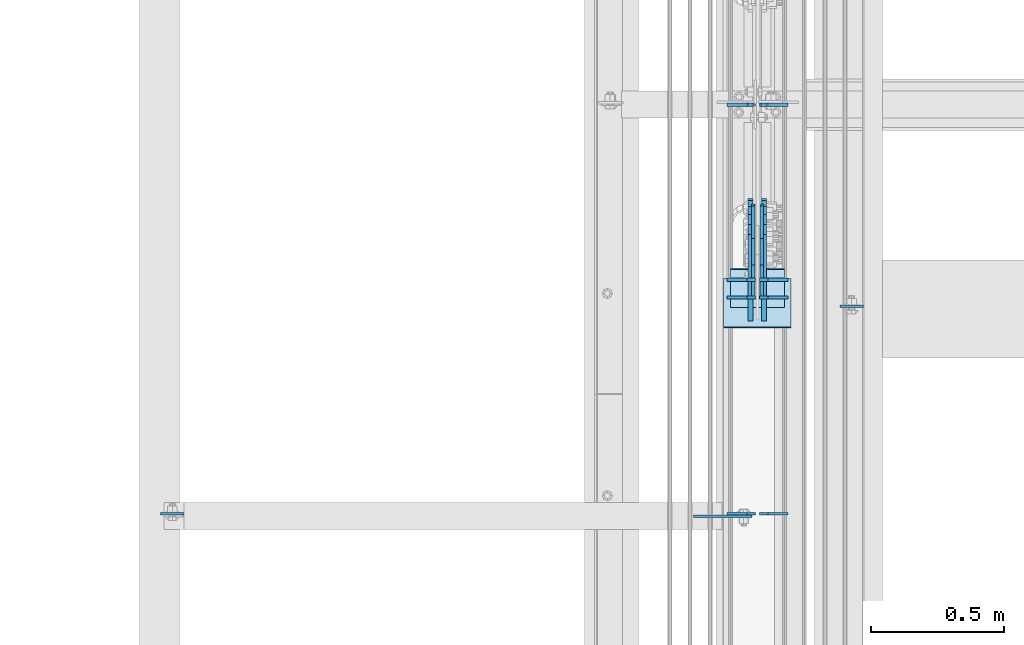
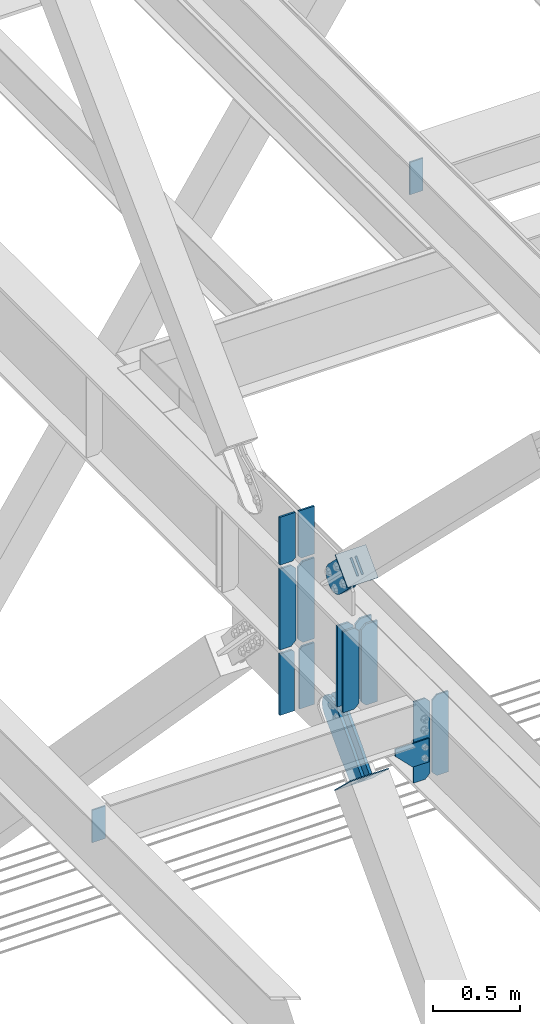
# One storey, part 3530 of 3843: 21 plates, 10 elements without a shape of their own.
"""IFC2X3 building model written with IfcOpenShell, lengths in millimetres."""

from ifc_helpers import new_model, si_unit, frame, origin_with_axes, place, context, subcontext, project, spatial, faceted_brep, material, type_object, element, aggregate, save


model = new_model("IFC2X3")

# Units and contexts
model_context = context("Model", 3, precision=1e-05, world=origin_with_axes())
body_context = subcontext(model_context, "Body", "Model", "MODEL_VIEW")
ifc_project = project(units=[si_unit("LENGTHUNIT", "METRE", prefix="MILLI"), si_unit("AREAUNIT", "SQUARE_METRE"), si_unit("VOLUMEUNIT", "CUBIC_METRE"), si_unit("MASSUNIT", "GRAM", prefix="KILO"), si_unit("TIMEUNIT", "SECOND"), si_unit("PLANEANGLEUNIT", "RADIAN"), si_unit("SOLIDANGLEUNIT", "STERADIAN"), si_unit("THERMODYNAMICTEMPERATUREUNIT", "DEGREE_CELSIUS"), si_unit("LUMINOUSINTENSITYUNIT", "LUMEN")], contexts=[model_context])

# Site, building, storey
site_placement = place(None, origin_with_axes())
site = spatial("IfcSite", under=ifc_project, at=site_placement, CompositionType="ELEMENT")
building_placement = place(site_placement, origin_with_axes())
building = spatial("IfcBuilding", under=site, at=building_placement, Name="Undefined", CompositionType="ELEMENT")
storey_placement = place(building_placement, origin_with_axes())
storey = spatial("IfcBuildingStorey", under=building, at=storey_placement, Name="Undefined", CompositionType="ELEMENT", Elevation=0.0)

# Assembly, plate
assembly_1_placement = place(storey_placement, origin_with_axes())
assembly_1 = element("IfcElementAssembly", 1, at=assembly_1_placement, inside=storey, Name="BEAM", AssemblyPlace="NOTDEFINED", PredefinedType="RIGID_FRAME")
ifc_material_1 = material(Name="STEEL/A572-50")
plate_type_1 = type_object("IfcPlateType", PredefinedType="NOTDEFINED")
plate_1_placement = place(assembly_1_placement, frame((77323.15625, 97627.082821, 39573.2), z_axis=(1.0, 0.0, 0.0), x_axis=(0.0, 0.0, -1.0)))
plate_1 = element("IfcPlate", 2, at=plate_1_placement, type_object=plate_type_1, material=ifc_material_1, Name="PLATE", context=body_context, shape_type="Brep", body=[
    faceted_brep([(0.0, -4.76249999999709, 0.0), (0.0, -4.76249999999709, 88.9000015258789), (0.0, 4.76249999999709, 88.9000015258789), (0.0, 4.76249999999709, 0.0), (228.600006102781, -4.7625000004191, 88.9000015257589), (228.600006102781, 4.76249999954598, 88.9000015257443), (228.600006103079, -4.7625000004482, 7.27595761418343e-12), (228.600006103079, 4.76249999954598, -7.27595761418343e-12)], [[[0, 1, 2, 3]], [[1, 4, 5, 2]], [[4, 6, 7, 5]], [[6, 0, 3, 7]], [[5, 7, 3, 2]], [[6, 4, 1, 0]]]),
])
aggregate(assembly_1, [plate_1])

assembly_2_placement = place(storey_placement, origin_with_axes())
assembly_2 = element("IfcElementAssembly", 3, at=assembly_2_placement, inside=storey, Name="BEAM", AssemblyPlace="NOTDEFINED", PredefinedType="RIGID_FRAME")
plate_2_placement = place(assembly_2_placement, frame((74764.503124, 96845.4375, 36398.2000000005), z_axis=(1.0, 0.0, 0.0), x_axis=(0.0, 0.0, -1.0)))
plate_2 = element("IfcPlate", 4, at=plate_2_placement, type_object=plate_type_1, material=ifc_material_1, Name="PLATE", context=body_context, shape_type="Brep", body=[
    faceted_brep([(0.0, -4.76249999999709, 0.0), (0.0, -4.76249999999709, 88.9000015258789), (0.0, 4.76249999999709, 88.9000015258789), (0.0, 4.76249999999709, 0.0), (228.600006102781, -4.7625000004191, 88.9000015257589), (228.600006102781, 4.76249999954598, 88.9000015257443), (228.600006103079, -4.7625000004482, 7.27595761418343e-12), (228.600006103079, 4.76249999954598, -7.27595761418343e-12)], [[[0, 1, 2, 3]], [[1, 4, 5, 2]], [[4, 6, 7, 5]], [[6, 0, 3, 7]], [[5, 7, 3, 2]], [[6, 4, 1, 0]]]),
])
aggregate(assembly_2, [plate_2])

# Assembly, plates
assembly_3_placement = place(storey_placement, origin_with_axes())
assembly_3 = element("IfcElementAssembly", 5, at=assembly_3_placement, inside=storey, Name="BEAM", AssemblyPlace="NOTDEFINED", PredefinedType="RIGID_FRAME")
plate_type_2 = type_object("IfcPlateType", PredefinedType="NOTDEFINED")
plate_3_placement = place(assembly_3_placement, frame((77019.94375, 96845.4379999161, 35840.9875), z_axis=(0.0, 0.0, 1.0), x_axis=(1.0, 0.0, 0.0)))
plate_3 = element("IfcPlate", 6, at=plate_3_placement, type_object=plate_type_2, material=ifc_material_1, Name="PLATE", context=body_context, shape_type="Brep", body=[
    faceted_brep([(0.0, -4.76249999999709, 31.75), (0.0, -4.76249999999709, 536.575012207031), (0.0, 4.76249999999709, 536.575012207031), (0.0, 4.76249999999709, 31.75), (31.75, -4.76249999999709, 568.325012207031), (31.75, 4.76249999999709, 568.325012207031), (107.15625, -4.76249999999709, 568.325012207031), (107.15625, 4.76249999999709, 568.325012207031), (107.15625, -4.76249999999709, 0.0), (107.15625, 4.76249999999709, 0.0), (31.75, -4.76249999999709, 0.0), (31.75, 4.76249999999709, 0.0)], [[[0, 1, 2, 3]], [[1, 4, 5, 2]], [[4, 6, 7, 5]], [[6, 8, 9, 7]], [[8, 10, 11, 9]], [[10, 0, 3, 11]], [[5, 7, 9, 11, 3, 2]], [[10, 8, 6, 4, 1, 0]]]),
])
plate_4_placement = place(assembly_3_placement, frame((77005.65625, 96845.4379999161, 35840.9875), z_axis=(0.0, 0.0, 1.0), x_axis=(-1.0, 0.0, 0.0)))
plate_4 = element("IfcPlate", 7, at=plate_4_placement, type_object=plate_type_2, material=ifc_material_1, Name="PLATE", context=body_context, shape_type="Brep", body=[
    faceted_brep([(0.0, -4.76249999999709, 31.75), (0.0, -4.76249999999709, 538.162475585938), (0.0, 4.76249999999709, 538.162475585938), (0.0, 4.76249999999709, 31.75), (31.75, -4.76249999999709, 569.912475585938), (31.75, 4.76249999999709, 569.912475585938), (107.949996948242, -4.76249999999709, 569.912475585938), (107.949996948242, 4.76249999999709, 569.912475585938), (107.950000000012, -4.76249999999709, 0.0), (107.950000000012, 4.76249999999709, 0.0), (31.75, -4.76249999999709, 0.0), (31.75, 4.76249999999709, 0.0)], [[[0, 1, 2, 3]], [[1, 4, 5, 2]], [[4, 6, 7, 5]], [[6, 8, 9, 7]], [[8, 10, 11, 9]], [[10, 0, 3, 11]], [[5, 7, 9, 11, 3, 2]], [[10, 8, 6, 4, 1, 0]]]),
])
plate_type_3 = type_object("IfcPlateType", PredefinedType="NOTDEFINED")
plate_5_placement = place(assembly_3_placement, frame((77005.65625, 97660.4854154961, 35840.9875), z_axis=(-1.0, 0.0, 0.0), x_axis=(0.0, 0.0, 1.0)))
plate_5 = element("IfcPlate", 8, at=plate_5_placement, type_object=plate_type_3, material=ifc_material_1, Name="CB_BEAM", context=body_context, shape_type="Brep", body=[
    faceted_brep([(0.0, -6.35000000000582, 31.75), (0.0, -6.35000000000582, 107.15625), (0.0, 6.35000000000582, 107.15625), (0.0, 6.35000000000582, 31.75), (568.324999999997, -6.35000000000582, 107.15625), (568.324999999997, 6.35000000000582, 107.15625), (568.324999999997, -6.35000000000582, 31.75), (568.324999999997, 6.35000000000582, 31.75), (536.574999999997, -6.35000000000582, 0.0), (536.574999999997, 6.35000000000582, 0.0), (31.75, -6.35000000000582, 0.0), (31.75, 6.35000000000582, 0.0)], [[[0, 1, 2, 3]], [[1, 4, 5, 2]], [[4, 6, 7, 5]], [[6, 8, 9, 7]], [[8, 10, 11, 9]], [[10, 0, 3, 11]], [[5, 7, 9, 11, 3, 2]], [[10, 8, 6, 4, 1, 0]]]),
])
plate_6_placement = place(assembly_3_placement, frame((77019.94375, 97660.4854154961, 35840.9875), z_axis=(1.0, 0.0, 0.0), x_axis=(0.0, 0.0, 1.0)))
plate_6 = element("IfcPlate", 9, at=plate_6_placement, type_object=plate_type_3, material=ifc_material_1, Name="CB_BEAM", context=body_context, shape_type="Brep", body=[
    faceted_brep([(0.0, -6.35000000000582, 31.75), (0.0, -6.35000000000582, 107.15625), (0.0, 6.35000000000582, 107.15625), (0.0, 6.35000000000582, 31.75), (568.324999999997, -6.35000000000582, 107.15625), (568.324999999997, 6.35000000000582, 107.15625), (568.324999999997, -6.35000000000582, 31.75), (568.324999999997, 6.35000000000582, 31.75), (536.574999999997, -6.35000000000582, 0.0), (536.574999999997, 6.35000000000582, 0.0), (31.75, -6.35000000000582, 0.0), (31.75, 6.35000000000582, 0.0)], [[[0, 1, 2, 3]], [[1, 4, 5, 2]], [[4, 6, 7, 5]], [[6, 8, 9, 7]], [[8, 10, 11, 9]], [[10, 0, 3, 11]], [[5, 7, 9, 11, 3, 2]], [[10, 8, 6, 4, 1, 0]]]),
])
plate_7_placement = place(assembly_3_placement, frame((77005.65625, 97726.6923283899, 35840.9875), z_axis=(-1.0, 0.0, 0.0), x_axis=(0.0, 0.0, 1.0)))
plate_7 = element("IfcPlate", 10, at=plate_7_placement, type_object=plate_type_3, material=ifc_material_1, Name="CB_BEAM", context=body_context, shape_type="Brep", body=[
    faceted_brep([(0.0, -6.35000000000582, 31.75), (0.0, -6.35000000000582, 107.15625), (0.0, 6.35000000000582, 107.15625), (0.0, 6.35000000000582, 31.75), (568.324999999997, -6.35000000000582, 107.15625), (568.324999999997, 6.35000000000582, 107.15625), (568.324999999997, -6.35000000000582, 31.75), (568.324999999997, 6.35000000000582, 31.75), (536.574999999997, -6.35000000000582, 0.0), (536.574999999997, 6.35000000000582, 0.0), (31.75, -6.35000000000582, 0.0), (31.75, 6.35000000000582, 0.0)], [[[0, 1, 2, 3]], [[1, 4, 5, 2]], [[4, 6, 7, 5]], [[6, 8, 9, 7]], [[8, 10, 11, 9]], [[10, 0, 3, 11]], [[5, 7, 9, 11, 3, 2]], [[10, 8, 6, 4, 1, 0]]]),
])
plate_8_placement = place(assembly_3_placement, frame((77019.94375, 97726.6923283899, 35840.9875), z_axis=(1.0, 0.0, 0.0), x_axis=(0.0, 0.0, 1.0)))
plate_8 = element("IfcPlate", 11, at=plate_8_placement, type_object=plate_type_3, material=ifc_material_1, Name="CB_BEAM", context=body_context, shape_type="Brep", body=[
    faceted_brep([(0.0, -6.35000000000582, 31.75), (0.0, -6.35000000000582, 107.15625), (0.0, 6.35000000000582, 107.15625), (0.0, 6.35000000000582, 31.75), (568.324999999997, -6.35000000000582, 107.15625), (568.324999999997, 6.35000000000582, 107.15625), (568.324999999997, -6.35000000000582, 31.75), (568.324999999997, 6.35000000000582, 31.75), (536.574999999997, -6.35000000000582, 0.0), (536.574999999997, 6.35000000000582, 0.0), (31.75, -6.35000000000582, 0.0), (31.75, 6.35000000000582, 0.0)], [[[0, 1, 2, 3]], [[1, 4, 5, 2]], [[4, 6, 7, 5]], [[6, 8, 9, 7]], [[8, 10, 11, 9]], [[10, 0, 3, 11]], [[5, 7, 9, 11, 3, 2]], [[10, 8, 6, 4, 1, 0]]]),
])
plate_9_placement = place(assembly_3_placement, frame((77005.65625, 98386.9000005101, 35840.9875), z_axis=(-1.0, 0.0, 0.0), x_axis=(0.0, 0.0, 1.0)))
plate_9 = element("IfcPlate", 12, at=plate_9_placement, type_object=plate_type_3, material=ifc_material_1, Name="CB_BEAM", context=body_context, shape_type="Brep", body=[
    faceted_brep([(0.0, -6.35000000000582, 31.75), (0.0, -6.35000000000582, 107.15625), (0.0, 6.35000000000582, 107.15625), (0.0, 6.35000000000582, 31.75), (568.324999999997, -6.35000000000582, 107.15625), (568.324999999997, 6.35000000000582, 107.15625), (568.324999999997, -6.35000000000582, 31.75), (568.324999999997, 6.35000000000582, 31.75), (536.574999999997, -6.35000000000582, 0.0), (536.574999999997, 6.35000000000582, 0.0), (31.75, -6.35000000000582, 0.0), (31.75, 6.35000000000582, 0.0)], [[[0, 1, 2, 3]], [[1, 4, 5, 2]], [[4, 6, 7, 5]], [[6, 8, 9, 7]], [[8, 10, 11, 9]], [[10, 0, 3, 11]], [[5, 7, 9, 11, 3, 2]], [[10, 8, 6, 4, 1, 0]]]),
])
plate_10_placement = place(assembly_3_placement, frame((77019.94375, 98386.9000005101, 35840.9875), z_axis=(1.0, 0.0, 0.0), x_axis=(0.0, 0.0, 1.0)))
plate_10 = element("IfcPlate", 13, at=plate_10_placement, type_object=plate_type_3, material=ifc_material_1, Name="CB_BEAM", context=body_context, shape_type="Brep", body=[
    faceted_brep([(0.0, -6.35000000000582, 31.75), (0.0, -6.35000000000582, 107.15625), (0.0, 6.35000000000582, 107.15625), (0.0, 6.35000000000582, 31.75), (568.324999999997, -6.35000000000582, 107.15625), (568.324999999997, 6.35000000000582, 107.15625), (568.324999999997, -6.35000000000582, 31.75), (568.324999999997, 6.35000000000582, 31.75), (536.574999999997, -6.35000000000582, 0.0), (536.574999999997, 6.35000000000582, 0.0), (31.75, -6.35000000000582, 0.0), (31.75, 6.35000000000582, 0.0)], [[[0, 1, 2, 3]], [[1, 4, 5, 2]], [[4, 6, 7, 5]], [[6, 8, 9, 7]], [[8, 10, 11, 9]], [[10, 0, 3, 11]], [[5, 7, 9, 11, 3, 2]], [[10, 8, 6, 4, 1, 0]]]),
])
plate_type_4 = type_object("IfcPlateType", PredefinedType="NOTDEFINED")
plate_11_placement = place(assembly_3_placement, frame((77003.275, 98386.9000021562, 36436.3), z_axis=(-1.0, 0.0, 0.0), x_axis=(0.0, 0.0, 1.0)))
plate_11 = element("IfcPlate", 14, at=plate_11_placement, type_object=plate_type_4, material=ifc_material_1, Name="CB", context=body_context, shape_type="Brep", body=[
    faceted_brep([(0.0, -6.34999999999854, 19.0499992370605), (0.0, -6.34999999999854, 104.775000000009), (0.0, 6.34999999999854, 104.775000000009), (0.0, 6.34999999999854, 19.0499992370605), (334.841042159038, -6.35000000000582, 104.775000000009), (334.841042159038, 6.35000000000582, 104.775000000009), (334.841042159038, -6.35000000000582, 0.0), (334.841042159038, 6.35000000000582, 0.0), (19.0499992370605, -6.34999999999854, 0.0), (19.0499992370605, 6.34999999999854, 0.0)], [[[0, 1, 2, 3]], [[1, 4, 5, 2]], [[4, 6, 7, 5]], [[6, 8, 9, 7]], [[8, 0, 3, 9]], [[5, 7, 9, 3, 2]], [[8, 6, 4, 1, 0]]]),
])
plate_12_placement = place(assembly_3_placement, frame((77022.325, 98386.9000021562, 36436.3), z_axis=(1.0, 0.0, 0.0), x_axis=(0.0, 0.0, 1.0)))
plate_12 = element("IfcPlate", 15, at=plate_12_placement, type_object=plate_type_4, material=ifc_material_1, Name="CB", context=body_context, shape_type="Brep", body=[
    faceted_brep([(0.0, -6.34999999999854, 19.0499992370605), (0.0, -6.34999999999854, 104.775000000009), (0.0, 6.34999999999854, 104.775000000009), (0.0, 6.34999999999854, 19.0499992370605), (334.841042159038, -6.35000000000582, 104.775000000009), (334.841042159038, 6.35000000000582, 104.775000000009), (334.841042159038, -6.35000000000582, 0.0), (334.841042159038, 6.35000000000582, 0.0), (19.0499992370605, -6.34999999999854, 0.0), (19.0499992370605, 6.34999999999854, 0.0)], [[[0, 1, 2, 3]], [[1, 4, 5, 2]], [[4, 6, 7, 5]], [[6, 8, 9, 7]], [[8, 0, 3, 9]], [[5, 7, 9, 3, 2]], [[8, 6, 4, 1, 0]]]),
])

# Assembly, plate
assembly_4_placement = place(storey_placement, origin_with_axes())
assembly_4 = element("IfcElementAssembly", 16, at=assembly_4_placement, inside=storey, Name="Plate", AssemblyPlace="NOTDEFINED", PredefinedType="RIGID_FRAME")
ifc_material_2 = material(Name="STEEL/A36")
plate_type_5 = type_object("IfcPlateType", PredefinedType="NOTDEFINED")
plate_13_placement = place(assembly_4_placement, frame((76911.2, 97625.3326219087, 36731.8524209083), z_axis=(0.0, 0.701307718956815, 0.712858669956107), x_axis=(1.0, 0.0, 0.0)))
plate_13 = element("IfcPlate", 17, at=plate_13_placement, type_object=plate_type_5, material=ifc_material_2, Name="Plate", context=body_context, shape_type="Brep", body=[
    faceted_brep([(0.0, -3.17499999999927, 0.0), (0.0, -3.17500000043947, 203.200000001736), (0.0, 3.1749999995518, 203.200000001743), (0.0, 3.17499999999927, 0.0), (203.200000000012, -3.17500000043947, 203.200000001736), (203.200000000012, 3.1749999995518, 203.200000001743), (203.199996948242, -3.17499999999927, 0.0), (203.199996948242, 3.17499999999927, 0.0)], [[[0, 1, 2, 3]], [[1, 4, 5, 2]], [[4, 6, 7, 5]], [[6, 0, 3, 7]], [[5, 7, 3, 2]], [[6, 4, 1, 0]]]),
])
aggregate(assembly_4, [plate_13])

assembly_5_placement = place(storey_placement, origin_with_axes())
assembly_5 = element("IfcElementAssembly", 18, at=assembly_5_placement, inside=storey, Name="BEAM", AssemblyPlace="NOTDEFINED", PredefinedType="RIGID_FRAME")
plate_type_6 = type_object("IfcPlateType", PredefinedType="NOTDEFINED")
plate_14_placement = place(assembly_5_placement, frame((76771.4999969482, 96835.9125, 36128.325), z_axis=(0.0, 0.0, -1.0), x_axis=(1.0, 0.0, 0.0)))
plate_14 = element("IfcPlate", 19, at=plate_14_placement, type_object=plate_type_6, material=ifc_material_1, Name="PLATE", context=body_context, shape_type="Brep", body=[
    faceted_brep([(0.0, -4.76249999999709, 0.0), (0.0, -4.76249999999709, 50.7999999999993), (0.0, 4.76249999999709, 50.7999999999993), (0.0, 4.76249999999709, 0.0), (114.300003051758, -4.76249999999709, 165.100006103516), (114.300003051758, 4.76249999999709, 165.100006103516), (221.456237792969, -4.76249999999709, 165.100006103516), (221.456237792969, 4.76249999999709, 165.100006103516), (221.456237792969, -4.76249999999709, 0.0), (221.456237792969, 4.76249999999709, 0.0)], [[[0, 1, 2, 3]], [[1, 4, 5, 2]], [[4, 6, 7, 5]], [[6, 8, 9, 7]], [[8, 0, 3, 9]], [[5, 7, 9, 3, 2]], [[8, 6, 4, 1, 0]]]),
])
aggregate(assembly_5, [plate_14])

assembly_6_placement = place(storey_placement, origin_with_axes())
assembly_6 = element("IfcElementAssembly", 20, at=assembly_6_placement, inside=storey, AssemblyPlace="NOTDEFINED", PredefinedType="RIGID_FRAME")
plate_type_7 = type_object("IfcPlateType", PredefinedType="NOTDEFINED")
plate_15_placement = place(assembly_6_placement, frame((76987.4, 97701.41391632, 35279.4656919276), z_axis=(0.0, -0.722239942286859, 0.691642585274702), x_axis=(0.0, 0.691642585274703, 0.722239942286858)))
plate_15 = element("IfcPlate", 21, at=plate_15_placement, type_object=plate_type_7, material=ifc_material_2, context=body_context, shape_type="Brep", body=[
    faceted_brep([(0.0, -9.52500000000146, 0.0), (7.37782102078199e-09, -9.52499999999418, 179.651701450231), (7.37782102078199e-09, 9.52499999999418, 179.651701450231), (0.0, 9.52500000000146, 0.0), (69.8500000062704, -9.52499999999418, 179.651701450392), (69.8500000062704, 9.52499999999418, 179.651701450392), (171.449999998309, -9.52499999999418, 186.663350727089), (171.449999998309, 9.52499999999418, 186.663350727089), (434.579297655291, -9.52499999999418, 186.663350728457), (434.579297655291, 9.52499999999418, 186.663350728457), (471.637405120986, -9.52499999999418, 179.292034842016), (471.637405120986, 9.52499999999418, 179.292034842016), (503.05375165752, -9.52499999999418, 158.300303204887), (503.05375165752, 9.52499999999418, 158.300303204887), (524.045483294532, -9.52499999999418, 126.883956668345), (524.045483294532, 9.52499999999418, 126.883956668345), (531.416799180792, -9.52499999999418, 89.8258522538526), (531.416799180792, 9.52499999999418, 89.8258522538526), (524.045483293885, -9.52499999999418, 52.7677447886235), (524.045483293885, 9.52499999999418, 52.7677447886235), (503.053751656611, -9.52499999999418, 21.3513982523873), (503.053751656611, 9.52499999999418, 21.3513982523873), (471.637405120178, -9.52499999999418, 0.359666615346214), (471.637405120178, 9.52499999999418, 0.359666615346214), (434.579299181831, -9.52499999999418, -7.01164927131322), (434.579299181831, 9.52499999999418, -7.01164927131322), (171.449999996272, -9.52499999999418, -7.01164927269565), (171.449999996272, 9.52499999999418, -7.01164927269565), (69.8499999979995, -9.52499999999418, -4.00177668780088e-10), (69.8499999979995, 9.52499999999418, -4.00177668780088e-10)], [[[0, 1, 2, 3]], [[1, 4, 5, 2]], [[4, 6, 7, 5]], [[6, 8, 9, 7]], [[8, 10, 11, 9]], [[10, 12, 13, 11]], [[12, 14, 15, 13]], [[14, 16, 17, 15]], [[16, 18, 19, 17]], [[18, 20, 21, 19]], [[20, 22, 23, 21]], [[22, 24, 25, 23]], [[24, 26, 27, 25]], [[26, 28, 29, 27]], [[28, 0, 3, 29]], [[5, 7, 9, 11, 13, 15, 17, 19, 21, 23, 25, 27, 29, 3, 2]], [[28, 26, 24, 22, 20, 18, 16, 14, 12, 10, 8, 6, 4, 1, 0]]]),
])
aggregate(assembly_6, [plate_15])

assembly_7_placement = place(storey_placement, origin_with_axes())
assembly_7 = element("IfcElementAssembly", 22, at=assembly_7_placement, inside=storey, AssemblyPlace="NOTDEFINED", PredefinedType="RIGID_FRAME")
plate_16_placement = place(assembly_7_placement, frame((77038.2, 97701.41391632, 35279.4656919276), z_axis=(0.0, -0.722239942286859, 0.691642585274702), x_axis=(0.0, 0.691642585274703, 0.722239942286858)))
plate_16 = element("IfcPlate", 23, at=plate_16_placement, type_object=plate_type_7, material=ifc_material_2, context=body_context, shape_type="Brep", body=[
    faceted_brep([(0.0, -9.52500000000146, 0.0), (7.37782102078199e-09, -9.52499999999418, 179.651701450231), (7.37782102078199e-09, 9.52499999999418, 179.651701450231), (0.0, 9.52500000000146, 0.0), (69.8500000062704, -9.52499999999418, 179.651701450392), (69.8500000062704, 9.52499999999418, 179.651701450392), (171.449999998309, -9.52499999999418, 186.663350727089), (171.449999998309, 9.52499999999418, 186.663350727089), (434.579297655291, -9.52499999999418, 186.663350728457), (434.579297655291, 9.52499999999418, 186.663350728457), (471.637405120986, -9.52499999999418, 179.292034842016), (471.637405120986, 9.52499999999418, 179.292034842016), (503.05375165752, -9.52499999999418, 158.300303204887), (503.05375165752, 9.52499999999418, 158.300303204887), (524.045483294532, -9.52499999999418, 126.883956668345), (524.045483294532, 9.52499999999418, 126.883956668345), (531.416799180792, -9.52499999999418, 89.8258522538526), (531.416799180792, 9.52499999999418, 89.8258522538526), (524.045483293885, -9.52499999999418, 52.7677447886235), (524.045483293885, 9.52499999999418, 52.7677447886235), (503.053751656611, -9.52499999999418, 21.3513982523873), (503.053751656611, 9.52499999999418, 21.3513982523873), (471.637405120178, -9.52499999999418, 0.359666615346214), (471.637405120178, 9.52499999999418, 0.359666615346214), (434.579299181831, -9.52499999999418, -7.01164927131322), (434.579299181831, 9.52499999999418, -7.01164927131322), (171.449999996272, -9.52499999999418, -7.01164927269565), (171.449999996272, 9.52499999999418, -7.01164927269565), (69.8499999979995, -9.52499999999418, -4.00177668780088e-10), (69.8499999979995, 9.52499999999418, -4.00177668780088e-10)], [[[0, 1, 2, 3]], [[1, 4, 5, 2]], [[4, 6, 7, 5]], [[6, 8, 9, 7]], [[8, 10, 11, 9]], [[10, 12, 13, 11]], [[12, 14, 15, 13]], [[14, 16, 17, 15]], [[16, 18, 19, 17]], [[18, 20, 21, 19]], [[20, 22, 23, 21]], [[22, 24, 25, 23]], [[24, 26, 27, 25]], [[26, 28, 29, 27]], [[28, 0, 3, 29]], [[5, 7, 9, 11, 13, 15, 17, 19, 21, 23, 25, 27, 29, 3, 2]], [[28, 26, 24, 22, 20, 18, 16, 14, 12, 10, 8, 6, 4, 1, 0]]]),
])
aggregate(assembly_7, [plate_16])

assembly_8_placement = place(storey_placement, origin_with_axes())
assembly_8 = element("IfcElementAssembly", 24, at=assembly_8_placement, inside=storey, Name="Plate", AssemblyPlace="NOTDEFINED", PredefinedType="RIGID_FRAME")
plate_type_8 = type_object("IfcPlateType", PredefinedType="NOTDEFINED")
plate_17_placement = place(assembly_8_placement, frame((77139.8, 97730.4585369817, 35256.0475790762), z_axis=(0.0, -0.722239942286859, 0.691642585274702), x_axis=(-1.0, 0.0, 0.0)))
plate_17 = element("IfcPlate", 25, at=plate_17_placement, type_object=plate_type_8, material=ifc_material_2, Name="Plate", context=body_context, shape_type="Brep", body=[
    faceted_brep([(0.0, -3.17499999999927, 0.0), (0.0, -3.17499999965185, 254.000000005151), (0.0, 3.17500000035216, 254.000000005166), (0.0, 3.17499999999927, 0.0), (254.0, -3.17499999965185, 254.000000005151), (254.0, 3.17500000035216, 254.000000005166), (254.0, -3.17500000000291, 0.0), (254.0, 3.17499999999927, 1.45519152283669e-11)], [[[0, 1, 2, 3]], [[1, 4, 5, 2]], [[4, 6, 7, 5]], [[6, 0, 3, 7]], [[5, 7, 3, 2]], [[6, 4, 1, 0]]]),
])
aggregate(assembly_8, [plate_17])

# Plate
plate_type_9 = type_object("IfcPlateType", PredefinedType="NOTDEFINED")
plate_18_placement = place(assembly_3_placement, frame((76996.925, 98386.9000005101, 35380.810938), z_axis=(-1.0, 0.0, 0.0), x_axis=(0.0, 0.0, 1.0)))
plate_18 = element("IfcPlate", 26, at=plate_18_placement, type_object=plate_type_9, material=ifc_material_1, Name="CB", context=body_context, shape_type="Brep", body=[
    faceted_brep([(0.0, -6.3499999046162, 0.0), (0.0, -6.35000000000582, 98.4250000000029), (0.0, 6.35000000000582, 98.4250000000029), (7.27595761418343e-12, 6.3499999046162, 0.0), (433.12354683008, -6.35000000000582, 98.4250000000029), (433.12354683008, 6.35000000000582, 98.4250000000029), (433.12354683008, -6.35000000000582, 19.0499992370605), (433.12354683008, 6.35000000000582, 19.0499992370605), (414.07354759302, -6.35000000000582, 0.0), (414.07354759302, 6.35000000000582, 0.0)], [[[0, 1, 2, 3]], [[1, 4, 5, 2]], [[4, 6, 7, 5]], [[6, 8, 9, 7]], [[8, 0, 3, 9]], [[5, 7, 9, 3, 2]], [[8, 6, 4, 1, 0]]]),
])

plate_19_placement = place(assembly_3_placement, frame((77028.675, 98386.9000005101, 35380.810938), z_axis=(1.0, 0.0, 0.0), x_axis=(0.0, 0.0, 1.0)))
plate_19 = element("IfcPlate", 27, at=plate_19_placement, type_object=plate_type_9, material=ifc_material_1, Name="CB", context=body_context, shape_type="Brep", body=[
    faceted_brep([(0.0, -6.3499999046162, 0.0), (0.0, -6.35000000000582, 98.4250000000029), (0.0, 6.35000000000582, 98.4250000000029), (7.27595761418343e-12, 6.3499999046162, 0.0), (433.12354683008, -6.35000000000582, 98.4250000000029), (433.12354683008, 6.35000000000582, 98.4250000000029), (433.12354683008, -6.35000000000582, 19.0499992370605), (433.12354683008, 6.35000000000582, 19.0499992370605), (414.07354759302, -6.35000000000582, 0.0), (414.07354759302, 6.35000000000582, 0.0)], [[[0, 1, 2, 3]], [[1, 4, 5, 2]], [[4, 6, 7, 5]], [[6, 8, 9, 7]], [[8, 0, 3, 9]], [[5, 7, 9, 3, 2]], [[8, 6, 4, 1, 0]]]),
])

aggregate(assembly_3, [plate_5, plate_6, plate_7, plate_8, plate_9, plate_10, plate_18, plate_19, plate_11, plate_12, plate_3, plate_4])

# Assembly, plate
assembly_9_placement = place(storey_placement, origin_with_axes())
assembly_9 = element("IfcElementAssembly", 28, at=assembly_9_placement, inside=storey, AssemblyPlace="NOTDEFINED", PredefinedType="RIGID_FRAME")
plate_type_10 = type_object("IfcPlateType", PredefinedType="NOTDEFINED")
plate_20_placement = place(assembly_9_placement, frame((76996.925, 97733.6602386688, 36846.4915138987), z_axis=(0.0, -0.701307718956826, -0.712858669956096), x_axis=(0.0, 0.712858669956096, -0.701307718956826)))
plate_20 = element("IfcPlate", 29, at=plate_20_placement, type_object=plate_type_10, material=ifc_material_2, context=body_context, shape_type="Brep", body=[
    faceted_brep([(0.0, -6.3499999046162, 0.0), (4.9622030928731e-09, -6.35000000000582, 112.184930798256), (4.9622030928731e-09, 6.35000000000582, 112.184930798256), (7.27595761418343e-12, 6.3499999046162, 0.0), (69.8500000038475, -6.35000000000582, 112.184930798168), (69.8500000038475, 6.35000000000582, 112.184930798168), (171.450000003882, -6.35000000000582, 149.754965398664), (171.450000003882, 6.35000000000582, 149.754965398664), (315.219242329083, -6.35000000000582, 149.754965398519), (315.219242329083, 6.35000000000582, 149.754965398519), (351.06232873004, -6.35000000000582, 142.625332228003), (351.06232873004, 6.35000000000582, 142.625332228003), (381.448630144558, -6.35000000000582, 122.321854736569), (381.448630144558, 6.35000000000582, 122.321854736569), (401.752107634529, -6.35000000000582, 91.9355533209819), (401.752107634529, 6.35000000000582, 91.9355533209819), (408.881740803365, -6.35000000000582, 56.0924638688084), (408.881740803365, 6.35000000000582, 56.0924638688084), (401.75210763223, -6.35000000000582, 20.2493774701215), (401.75210763223, 6.35000000000582, 20.2493774701215), (381.448630141909, -6.35000000000582, -10.1369239423584), (381.448630141909, 6.35000000000582, -10.1369239423584), (351.062328728673, -6.35000000000582, -30.4404014313986), (351.062328728673, 6.35000000000582, -30.4404014313986), (315.219240800725, -6.35000000000582, -37.5700346009617), (315.219240800725, 6.35000000000582, -37.5700346009617), (171.449999995632, -6.35000000000582, -37.5700346008307), (171.449999995632, 6.35000000000582, -37.5700346008307), (69.8499999985434, -6.35000000000582, -8.73114913702011e-11), (69.8499999985434, 6.35000000000582, -8.73114913702011e-11)], [[[0, 1, 2, 3]], [[1, 4, 5, 2]], [[4, 6, 7, 5]], [[6, 8, 9, 7]], [[8, 10, 11, 9]], [[10, 12, 13, 11]], [[12, 14, 15, 13]], [[14, 16, 17, 15]], [[16, 18, 19, 17]], [[18, 20, 21, 19]], [[20, 22, 23, 21]], [[22, 24, 25, 23]], [[24, 26, 27, 25]], [[26, 28, 29, 27]], [[28, 0, 3, 29]], [[5, 7, 9, 11, 13, 15, 17, 19, 21, 23, 25, 27, 29, 3, 2]], [[28, 26, 24, 22, 20, 18, 16, 14, 12, 10, 8, 6, 4, 1, 0]]]),
])
aggregate(assembly_9, [plate_20])

assembly_10_placement = place(storey_placement, origin_with_axes())
assembly_10 = element("IfcElementAssembly", 30, at=assembly_10_placement, inside=storey, AssemblyPlace="NOTDEFINED", PredefinedType="RIGID_FRAME")
plate_21_placement = place(assembly_10_placement, frame((77028.675, 97733.6602386688, 36846.4915138987), z_axis=(0.0, -0.701307718956826, -0.712858669956096), x_axis=(0.0, 0.712858669956096, -0.701307718956826)))
plate_21 = element("IfcPlate", 31, at=plate_21_placement, type_object=plate_type_10, material=ifc_material_2, context=body_context, shape_type="Brep", body=[
    faceted_brep([(0.0, -6.3499999046162, 0.0), (4.9622030928731e-09, -6.35000000000582, 112.184930798256), (4.9622030928731e-09, 6.35000000000582, 112.184930798256), (7.27595761418343e-12, 6.3499999046162, 0.0), (69.8500000038475, -6.35000000000582, 112.184930798168), (69.8500000038475, 6.35000000000582, 112.184930798168), (171.450000003882, -6.35000000000582, 149.754965398664), (171.450000003882, 6.35000000000582, 149.754965398664), (315.219242329083, -6.35000000000582, 149.754965398519), (315.219242329083, 6.35000000000582, 149.754965398519), (351.06232873004, -6.35000000000582, 142.625332228003), (351.06232873004, 6.35000000000582, 142.625332228003), (381.448630144558, -6.35000000000582, 122.321854736569), (381.448630144558, 6.35000000000582, 122.321854736569), (401.752107634529, -6.35000000000582, 91.9355533209819), (401.752107634529, 6.35000000000582, 91.9355533209819), (408.881740803365, -6.35000000000582, 56.0924638688084), (408.881740803365, 6.35000000000582, 56.0924638688084), (401.75210763223, -6.35000000000582, 20.2493774701215), (401.75210763223, 6.35000000000582, 20.2493774701215), (381.448630141909, -6.35000000000582, -10.1369239423584), (381.448630141909, 6.35000000000582, -10.1369239423584), (351.062328728673, -6.35000000000582, -30.4404014313986), (351.062328728673, 6.35000000000582, -30.4404014313986), (315.219240800725, -6.35000000000582, -37.5700346009617), (315.219240800725, 6.35000000000582, -37.5700346009617), (171.449999995632, -6.35000000000582, -37.5700346008307), (171.449999995632, 6.35000000000582, -37.5700346008307), (69.8499999985434, -6.35000000000582, -8.73114913702011e-11), (69.8499999985434, 6.35000000000582, -8.73114913702011e-11)], [[[0, 1, 2, 3]], [[1, 4, 5, 2]], [[4, 6, 7, 5]], [[6, 8, 9, 7]], [[8, 10, 11, 9]], [[10, 12, 13, 11]], [[12, 14, 15, 13]], [[14, 16, 17, 15]], [[16, 18, 19, 17]], [[18, 20, 21, 19]], [[20, 22, 23, 21]], [[22, 24, 25, 23]], [[24, 26, 27, 25]], [[26, 28, 29, 27]], [[28, 0, 3, 29]], [[5, 7, 9, 11, 13, 15, 17, 19, 21, 23, 25, 27, 29, 3, 2]], [[28, 26, 24, 22, 20, 18, 16, 14, 12, 10, 8, 6, 4, 1, 0]]]),
])
aggregate(assembly_10, [plate_21])

save(model, "model.ifc")
